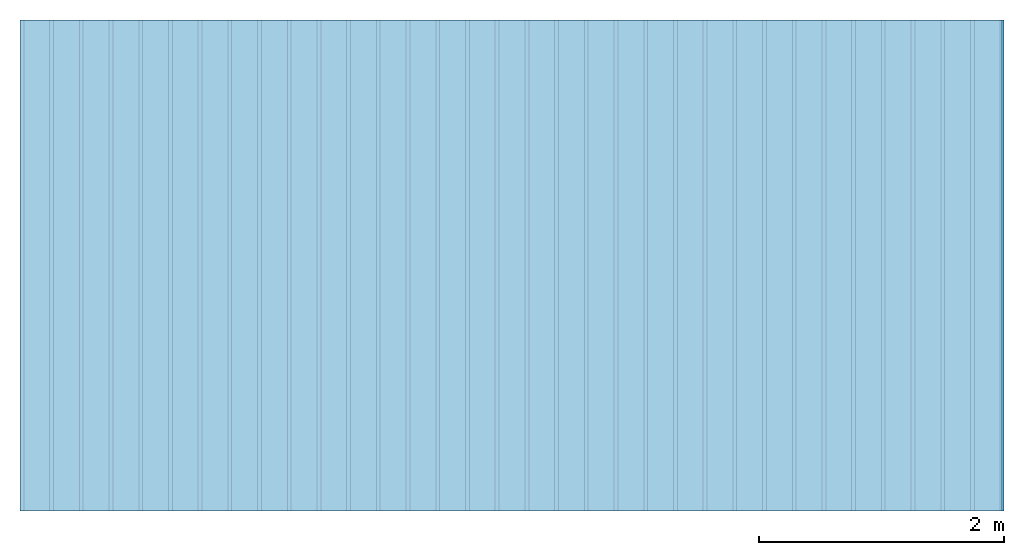
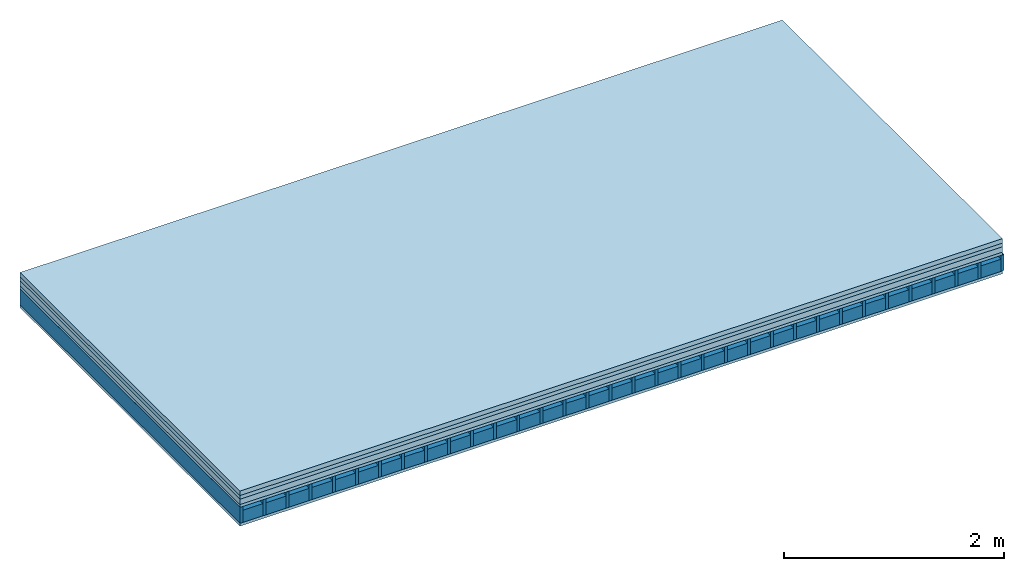
# One storey: 5 plates, 2 members, 1 element without a shape of its own.
"""IFC4 building model written with IfcOpenShell, lengths in metres."""

from ifc_helpers import new_model, si_unit, derived_unit, direction, frame, frame_2d, origin, origin_with_axes, place, context, project, spatial, rectangle, extrude, material, layer, layer_set, type_object, element, aggregate, save


model = new_model("IFC4")

# Units and contexts
plan_context = context("Plan", 3, precision=1e-05, world=origin(), true_north=direction((0.0, 1.0)))
model_context = context("Model", 3, precision=1e-05, world=origin(), true_north=direction((0.0, 1.0)))
ifc_project = project(units=[si_unit("LENGTHUNIT", "METRE"), derived_unit("SOUNDPRESSUREUNIT", [(si_unit("PRESSUREUNIT", "PASCAL", prefix="MICRO"), 0)]), si_unit("ENERGYUNIT", "JOULE", prefix="MEGA"), si_unit("MASSUNIT", "GRAM", prefix="KILO"), derived_unit("THERMALTRANSMITTANCEUNIT", [(si_unit("POWERUNIT", "WATT"), 1), (si_unit("AREAUNIT", "SQUARE_METRE"), -1), (si_unit("THERMODYNAMICTEMPERATUREUNIT", "KELVIN"), -1)]), derived_unit("AREADENSITYUNIT", [(si_unit("MASSUNIT", "GRAM", prefix="KILO"), 1), (si_unit("AREAUNIT", "SQUARE_METRE"), -1)]), derived_unit("USERDEFINED", [(si_unit("ENERGYUNIT", "JOULE", prefix="MEGA"), 1), (si_unit("AREAUNIT", "SQUARE_METRE"), -1)])], contexts=[plan_context, model_context])

# Site, building, storey
site = spatial("IfcSite", under=ifc_project)
building_placement = place(None, origin())
building = spatial("IfcBuilding", under=site, at=building_placement)
storey_placement = place(building_placement, origin())
storey = spatial("IfcBuildingStorey", under=building, at=storey_placement)

# Slab, members, plates
ifc_material_1 = material(Name="Cement screed", Category="04.006")
ifc_layer_1 = layer(ifc_material_1, 0.05, Name="On-material")
ifc_material_2 = material(Name="EP1, 40/35mm")
ifc_layer_2 = layer(ifc_material_2, 0.04, Name="Impact sound insulation")
ifc_material_3 = material(Category="03.011")
ifc_layer_3 = layer(ifc_material_3, 0.06, Name="on Supporting structure")
ifc_material_4 = material(Name="surface element sheathing above")
ifc_layer_4 = layer(ifc_material_4, 0.031, Name="Sub-floor")
ifc_layer_5 = layer(None, 0.178, Name="Supporting structure")
ifc_material_5 = material(Name="surface element acoustics type sheathing below 3")
ifc_layer_6 = layer(ifc_material_5, 0.031, Name="Lower layer 1")
ifc_layer_set = layer_set([ifc_layer_1, ifc_layer_2, ifc_layer_3, ifc_layer_4, ifc_layer_5, ifc_layer_6])
slab_type = type_object("IfcSlabType", Name="A1470", PredefinedType="NOTDEFINED", material=ifc_layer_set)
slab_placement = place(None, frame((0.0, 0.0, 0.0), z_axis=(0.0, 0.0, -1.0), x_axis=(1.0, 0.0, 0.0)))
slab = element("IfcSlab", 1, at=slab_placement, inside=storey, type_object=slab_type, material=ifc_layer_set, Name="Slab #1")
ifc_material_6 = material(Name="surface element LFE 12")
member_1_placement = place(slab_placement, origin())
member_1 = element("IfcMember", 2, at=member_1_placement, material=ifc_material_6, Name="Supporting structure", context=plan_context, shape_type="SweptSolid", body=[
    extrude(rectangle(XDim=0.031, YDim=0.178, at=frame_2d((0.0155, 0.089), x_axis=(1.0, 0.0))), frame((0.0, 4.0, 0.181), z_axis=(0.0, -1.0, 0.0), x_axis=(1.0, 0.0, 0.0)), (0.0, 0.0, 1.0), 4.0),
    extrude(rectangle(XDim=0.031, YDim=0.178, at=frame_2d((0.0155, 0.089), x_axis=(1.0, 0.0))), frame((0.242, 4.0, 0.181), z_axis=(0.0, -1.0, 0.0), x_axis=(1.0, 0.0, 0.0)), (0.0, 0.0, 1.0), 4.0),
    extrude(rectangle(XDim=0.031, YDim=0.178, at=frame_2d((0.0155, 0.089), x_axis=(1.0, 0.0))), frame((0.484, 4.0, 0.181), z_axis=(0.0, -1.0, 0.0), x_axis=(1.0, 0.0, 0.0)), (0.0, 0.0, 1.0), 4.0),
    extrude(rectangle(XDim=0.031, YDim=0.178, at=frame_2d((0.0155, 0.089), x_axis=(1.0, 0.0))), frame((0.726, 4.0, 0.181), z_axis=(0.0, -1.0, 0.0), x_axis=(1.0, 0.0, 0.0)), (0.0, 0.0, 1.0), 4.0),
    extrude(rectangle(XDim=0.031, YDim=0.178, at=frame_2d((0.0155, 0.089), x_axis=(1.0, 0.0))), frame((0.968, 4.0, 0.181), z_axis=(0.0, -1.0, 0.0), x_axis=(1.0, 0.0, 0.0)), (0.0, 0.0, 1.0), 4.0),
    extrude(rectangle(XDim=0.031, YDim=0.178, at=frame_2d((0.0155, 0.089), x_axis=(1.0, 0.0))), frame((1.21, 4.0, 0.181), z_axis=(0.0, -1.0, 0.0), x_axis=(1.0, 0.0, 0.0)), (0.0, 0.0, 1.0), 4.0),
    extrude(rectangle(XDim=0.031, YDim=0.178, at=frame_2d((0.0155, 0.089), x_axis=(1.0, 0.0))), frame((1.452, 4.0, 0.181), z_axis=(0.0, -1.0, 0.0), x_axis=(1.0, 0.0, 0.0)), (0.0, 0.0, 1.0), 4.0),
    extrude(rectangle(XDim=0.031, YDim=0.178, at=frame_2d((0.0155, 0.089), x_axis=(1.0, 0.0))), frame((1.694, 4.0, 0.181), z_axis=(0.0, -1.0, 0.0), x_axis=(1.0, 0.0, 0.0)), (0.0, 0.0, 1.0), 4.0),
    extrude(rectangle(XDim=0.031, YDim=0.178, at=frame_2d((0.0155, 0.089), x_axis=(1.0, 0.0))), frame((1.936, 4.0, 0.181), z_axis=(0.0, -1.0, 0.0), x_axis=(1.0, 0.0, 0.0)), (0.0, 0.0, 1.0), 4.0),
    extrude(rectangle(XDim=0.031, YDim=0.178, at=frame_2d((0.0155, 0.089), x_axis=(1.0, 0.0))), frame((2.178, 4.0, 0.181), z_axis=(0.0, -1.0, 0.0), x_axis=(1.0, 0.0, 0.0)), (0.0, 0.0, 1.0), 4.0),
    extrude(rectangle(XDim=0.031, YDim=0.178, at=frame_2d((0.0155, 0.089), x_axis=(1.0, 0.0))), frame((2.42, 4.0, 0.181), z_axis=(0.0, -1.0, 0.0), x_axis=(1.0, 0.0, 0.0)), (0.0, 0.0, 1.0), 4.0),
    extrude(rectangle(XDim=0.031, YDim=0.178, at=frame_2d((0.0155, 0.089), x_axis=(1.0, 0.0))), frame((2.662, 4.0, 0.181), z_axis=(0.0, -1.0, 0.0), x_axis=(1.0, 0.0, 0.0)), (0.0, 0.0, 1.0), 4.0),
    extrude(rectangle(XDim=0.031, YDim=0.178, at=frame_2d((0.0155, 0.089), x_axis=(1.0, 0.0))), frame((2.904, 4.0, 0.181), z_axis=(0.0, -1.0, 0.0), x_axis=(1.0, 0.0, 0.0)), (0.0, 0.0, 1.0), 4.0),
    extrude(rectangle(XDim=0.031, YDim=0.178, at=frame_2d((0.0155, 0.089), x_axis=(1.0, 0.0))), frame((3.146, 4.0, 0.181), z_axis=(0.0, -1.0, 0.0), x_axis=(1.0, 0.0, 0.0)), (0.0, 0.0, 1.0), 4.0),
    extrude(rectangle(XDim=0.031, YDim=0.178, at=frame_2d((0.0155, 0.089), x_axis=(1.0, 0.0))), frame((3.388, 4.0, 0.181), z_axis=(0.0, -1.0, 0.0), x_axis=(1.0, 0.0, 0.0)), (0.0, 0.0, 1.0), 4.0),
    extrude(rectangle(XDim=0.031, YDim=0.178, at=frame_2d((0.0155, 0.089), x_axis=(1.0, 0.0))), frame((3.63, 4.0, 0.181), z_axis=(0.0, -1.0, 0.0), x_axis=(1.0, 0.0, 0.0)), (0.0, 0.0, 1.0), 4.0),
    extrude(rectangle(XDim=0.031, YDim=0.178, at=frame_2d((0.0155, 0.089), x_axis=(1.0, 0.0))), frame((3.872, 4.0, 0.181), z_axis=(0.0, -1.0, 0.0), x_axis=(1.0, 0.0, 0.0)), (0.0, 0.0, 1.0), 4.0),
    extrude(rectangle(XDim=0.031, YDim=0.178, at=frame_2d((0.0155, 0.089), x_axis=(1.0, 0.0))), frame((4.114, 4.0, 0.181), z_axis=(0.0, -1.0, 0.0), x_axis=(1.0, 0.0, 0.0)), (0.0, 0.0, 1.0), 4.0),
    extrude(rectangle(XDim=0.031, YDim=0.178, at=frame_2d((0.0155, 0.089), x_axis=(1.0, 0.0))), frame((4.356, 4.0, 0.181), z_axis=(0.0, -1.0, 0.0), x_axis=(1.0, 0.0, 0.0)), (0.0, 0.0, 1.0), 4.0),
    extrude(rectangle(XDim=0.031, YDim=0.178, at=frame_2d((0.0155, 0.089), x_axis=(1.0, 0.0))), frame((4.598, 4.0, 0.181), z_axis=(0.0, -1.0, 0.0), x_axis=(1.0, 0.0, 0.0)), (0.0, 0.0, 1.0), 4.0),
    extrude(rectangle(XDim=0.031, YDim=0.178, at=frame_2d((0.0155, 0.089), x_axis=(1.0, 0.0))), frame((4.84, 4.0, 0.181), z_axis=(0.0, -1.0, 0.0), x_axis=(1.0, 0.0, 0.0)), (0.0, 0.0, 1.0), 4.0),
    extrude(rectangle(XDim=0.031, YDim=0.178, at=frame_2d((0.0155, 0.089), x_axis=(1.0, 0.0))), frame((5.082, 4.0, 0.181), z_axis=(0.0, -1.0, 0.0), x_axis=(1.0, 0.0, 0.0)), (0.0, 0.0, 1.0), 4.0),
    extrude(rectangle(XDim=0.031, YDim=0.178, at=frame_2d((0.0155, 0.089), x_axis=(1.0, 0.0))), frame((5.324, 4.0, 0.181), z_axis=(0.0, -1.0, 0.0), x_axis=(1.0, 0.0, 0.0)), (0.0, 0.0, 1.0), 4.0),
    extrude(rectangle(XDim=0.031, YDim=0.178, at=frame_2d((0.0155, 0.089), x_axis=(1.0, 0.0))), frame((5.566, 4.0, 0.181), z_axis=(0.0, -1.0, 0.0), x_axis=(1.0, 0.0, 0.0)), (0.0, 0.0, 1.0), 4.0),
    extrude(rectangle(XDim=0.031, YDim=0.178, at=frame_2d((0.0155, 0.089), x_axis=(1.0, 0.0))), frame((5.808, 4.0, 0.181), z_axis=(0.0, -1.0, 0.0), x_axis=(1.0, 0.0, 0.0)), (0.0, 0.0, 1.0), 4.0),
    extrude(rectangle(XDim=0.031, YDim=0.178, at=frame_2d((0.0155, 0.089), x_axis=(1.0, 0.0))), frame((6.05, 4.0, 0.181), z_axis=(0.0, -1.0, 0.0), x_axis=(1.0, 0.0, 0.0)), (0.0, 0.0, 1.0), 4.0),
    extrude(rectangle(XDim=0.031, YDim=0.178, at=frame_2d((0.0155, 0.089), x_axis=(1.0, 0.0))), frame((6.292, 4.0, 0.181), z_axis=(0.0, -1.0, 0.0), x_axis=(1.0, 0.0, 0.0)), (0.0, 0.0, 1.0), 4.0),
    extrude(rectangle(XDim=0.031, YDim=0.178, at=frame_2d((0.0155, 0.089), x_axis=(1.0, 0.0))), frame((6.534, 4.0, 0.181), z_axis=(0.0, -1.0, 0.0), x_axis=(1.0, 0.0, 0.0)), (0.0, 0.0, 1.0), 4.0),
    extrude(rectangle(XDim=0.031, YDim=0.178, at=frame_2d((0.0155, 0.089), x_axis=(1.0, 0.0))), frame((6.776, 4.0, 0.181), z_axis=(0.0, -1.0, 0.0), x_axis=(1.0, 0.0, 0.0)), (0.0, 0.0, 1.0), 4.0),
    extrude(rectangle(XDim=0.031, YDim=0.178, at=frame_2d((0.0155, 0.089), x_axis=(1.0, 0.0))), frame((7.018, 4.0, 0.181), z_axis=(0.0, -1.0, 0.0), x_axis=(1.0, 0.0, 0.0)), (0.0, 0.0, 1.0), 4.0),
    extrude(rectangle(XDim=0.031, YDim=0.178, at=frame_2d((0.0155, 0.089), x_axis=(1.0, 0.0))), frame((7.26, 4.0, 0.181), z_axis=(0.0, -1.0, 0.0), x_axis=(1.0, 0.0, 0.0)), (0.0, 0.0, 1.0), 4.0),
    extrude(rectangle(XDim=0.031, YDim=0.178, at=frame_2d((0.0155, 0.089), x_axis=(1.0, 0.0))), frame((7.502, 4.0, 0.181), z_axis=(0.0, -1.0, 0.0), x_axis=(1.0, 0.0, 0.0)), (0.0, 0.0, 1.0), 4.0),
    extrude(rectangle(XDim=0.031, YDim=0.178, at=frame_2d((0.0155, 0.089), x_axis=(1.0, 0.0))), frame((7.744, 4.0, 0.181), z_axis=(0.0, -1.0, 0.0), x_axis=(1.0, 0.0, 0.0)), (0.0, 0.0, 1.0), 4.0),
    extrude(rectangle(XDim=0.031, YDim=0.178, at=frame_2d((0.0155, 0.089), x_axis=(1.0, 0.0))), frame((7.986, 4.0, 0.181), z_axis=(0.0, -1.0, 0.0), x_axis=(1.0, 0.0, 0.0)), (0.0, 0.0, 1.0), 4.0),
])
ifc_material_7 = material(Name="Damper LFE 12")
member_2_placement = place(slab_placement, origin())
member_2 = element("IfcMember", 3, at=member_2_placement, material=ifc_material_7, Name="in supporting structure", context=plan_context, shape_type="SweptSolid", body=[
    extrude(rectangle(XDim=0.211, YDim=0.135, at=frame_2d((0.1055, 0.0675), x_axis=(1.0, 0.0))), frame((0.031, 4.0, 0.224), z_axis=(0.0, -1.0, 0.0), x_axis=(1.0, 0.0, 0.0)), (0.0, 0.0, 1.0), 4.0),
    extrude(rectangle(XDim=0.211, YDim=0.135, at=frame_2d((0.1055, 0.0675), x_axis=(1.0, 0.0))), frame((0.273, 4.0, 0.224), z_axis=(0.0, -1.0, 0.0), x_axis=(1.0, 0.0, 0.0)), (0.0, 0.0, 1.0), 4.0),
    extrude(rectangle(XDim=0.211, YDim=0.135, at=frame_2d((0.1055, 0.0675), x_axis=(1.0, 0.0))), frame((0.515, 4.0, 0.224), z_axis=(0.0, -1.0, 0.0), x_axis=(1.0, 0.0, 0.0)), (0.0, 0.0, 1.0), 4.0),
    extrude(rectangle(XDim=0.211, YDim=0.135, at=frame_2d((0.1055, 0.0675), x_axis=(1.0, 0.0))), frame((0.757, 4.0, 0.224), z_axis=(0.0, -1.0, 0.0), x_axis=(1.0, 0.0, 0.0)), (0.0, 0.0, 1.0), 4.0),
    extrude(rectangle(XDim=0.211, YDim=0.135, at=frame_2d((0.1055, 0.0675), x_axis=(1.0, 0.0))), frame((0.999, 4.0, 0.224), z_axis=(0.0, -1.0, 0.0), x_axis=(1.0, 0.0, 0.0)), (0.0, 0.0, 1.0), 4.0),
    extrude(rectangle(XDim=0.211, YDim=0.135, at=frame_2d((0.1055, 0.0675), x_axis=(1.0, 0.0))), frame((1.241, 4.0, 0.224), z_axis=(0.0, -1.0, 0.0), x_axis=(1.0, 0.0, 0.0)), (0.0, 0.0, 1.0), 4.0),
    extrude(rectangle(XDim=0.211, YDim=0.135, at=frame_2d((0.1055, 0.0675), x_axis=(1.0, 0.0))), frame((1.483, 4.0, 0.224), z_axis=(0.0, -1.0, 0.0), x_axis=(1.0, 0.0, 0.0)), (0.0, 0.0, 1.0), 4.0),
    extrude(rectangle(XDim=0.211, YDim=0.135, at=frame_2d((0.1055, 0.0675), x_axis=(1.0, 0.0))), frame((1.725, 4.0, 0.224), z_axis=(0.0, -1.0, 0.0), x_axis=(1.0, 0.0, 0.0)), (0.0, 0.0, 1.0), 4.0),
    extrude(rectangle(XDim=0.211, YDim=0.135, at=frame_2d((0.1055, 0.0675), x_axis=(1.0, 0.0))), frame((1.967, 4.0, 0.224), z_axis=(0.0, -1.0, 0.0), x_axis=(1.0, 0.0, 0.0)), (0.0, 0.0, 1.0), 4.0),
    extrude(rectangle(XDim=0.211, YDim=0.135, at=frame_2d((0.1055, 0.0675), x_axis=(1.0, 0.0))), frame((2.209, 4.0, 0.224), z_axis=(0.0, -1.0, 0.0), x_axis=(1.0, 0.0, 0.0)), (0.0, 0.0, 1.0), 4.0),
    extrude(rectangle(XDim=0.211, YDim=0.135, at=frame_2d((0.1055, 0.0675), x_axis=(1.0, 0.0))), frame((2.451, 4.0, 0.224), z_axis=(0.0, -1.0, 0.0), x_axis=(1.0, 0.0, 0.0)), (0.0, 0.0, 1.0), 4.0),
    extrude(rectangle(XDim=0.211, YDim=0.135, at=frame_2d((0.1055, 0.0675), x_axis=(1.0, 0.0))), frame((2.693, 4.0, 0.224), z_axis=(0.0, -1.0, 0.0), x_axis=(1.0, 0.0, 0.0)), (0.0, 0.0, 1.0), 4.0),
    extrude(rectangle(XDim=0.211, YDim=0.135, at=frame_2d((0.1055, 0.0675), x_axis=(1.0, 0.0))), frame((2.935, 4.0, 0.224), z_axis=(0.0, -1.0, 0.0), x_axis=(1.0, 0.0, 0.0)), (0.0, 0.0, 1.0), 4.0),
    extrude(rectangle(XDim=0.211, YDim=0.135, at=frame_2d((0.1055, 0.0675), x_axis=(1.0, 0.0))), frame((3.177, 4.0, 0.224), z_axis=(0.0, -1.0, 0.0), x_axis=(1.0, 0.0, 0.0)), (0.0, 0.0, 1.0), 4.0),
    extrude(rectangle(XDim=0.211, YDim=0.135, at=frame_2d((0.1055, 0.0675), x_axis=(1.0, 0.0))), frame((3.419, 4.0, 0.224), z_axis=(0.0, -1.0, 0.0), x_axis=(1.0, 0.0, 0.0)), (0.0, 0.0, 1.0), 4.0),
    extrude(rectangle(XDim=0.211, YDim=0.135, at=frame_2d((0.1055, 0.0675), x_axis=(1.0, 0.0))), frame((3.661, 4.0, 0.224), z_axis=(0.0, -1.0, 0.0), x_axis=(1.0, 0.0, 0.0)), (0.0, 0.0, 1.0), 4.0),
    extrude(rectangle(XDim=0.211, YDim=0.135, at=frame_2d((0.1055, 0.0675), x_axis=(1.0, 0.0))), frame((3.903, 4.0, 0.224), z_axis=(0.0, -1.0, 0.0), x_axis=(1.0, 0.0, 0.0)), (0.0, 0.0, 1.0), 4.0),
    extrude(rectangle(XDim=0.211, YDim=0.135, at=frame_2d((0.1055, 0.0675), x_axis=(1.0, 0.0))), frame((4.145, 4.0, 0.224), z_axis=(0.0, -1.0, 0.0), x_axis=(1.0, 0.0, 0.0)), (0.0, 0.0, 1.0), 4.0),
    extrude(rectangle(XDim=0.211, YDim=0.135, at=frame_2d((0.1055, 0.0675), x_axis=(1.0, 0.0))), frame((4.387, 4.0, 0.224), z_axis=(0.0, -1.0, 0.0), x_axis=(1.0, 0.0, 0.0)), (0.0, 0.0, 1.0), 4.0),
    extrude(rectangle(XDim=0.211, YDim=0.135, at=frame_2d((0.1055, 0.0675), x_axis=(1.0, 0.0))), frame((4.629, 4.0, 0.224), z_axis=(0.0, -1.0, 0.0), x_axis=(1.0, 0.0, 0.0)), (0.0, 0.0, 1.0), 4.0),
    extrude(rectangle(XDim=0.211, YDim=0.135, at=frame_2d((0.1055, 0.0675), x_axis=(1.0, 0.0))), frame((4.871, 4.0, 0.224), z_axis=(0.0, -1.0, 0.0), x_axis=(1.0, 0.0, 0.0)), (0.0, 0.0, 1.0), 4.0),
    extrude(rectangle(XDim=0.211, YDim=0.135, at=frame_2d((0.1055, 0.0675), x_axis=(1.0, 0.0))), frame((5.113, 4.0, 0.224), z_axis=(0.0, -1.0, 0.0), x_axis=(1.0, 0.0, 0.0)), (0.0, 0.0, 1.0), 4.0),
    extrude(rectangle(XDim=0.211, YDim=0.135, at=frame_2d((0.1055, 0.0675), x_axis=(1.0, 0.0))), frame((5.355, 4.0, 0.224), z_axis=(0.0, -1.0, 0.0), x_axis=(1.0, 0.0, 0.0)), (0.0, 0.0, 1.0), 4.0),
    extrude(rectangle(XDim=0.211, YDim=0.135, at=frame_2d((0.1055, 0.0675), x_axis=(1.0, 0.0))), frame((5.597, 4.0, 0.224), z_axis=(0.0, -1.0, 0.0), x_axis=(1.0, 0.0, 0.0)), (0.0, 0.0, 1.0), 4.0),
    extrude(rectangle(XDim=0.211, YDim=0.135, at=frame_2d((0.1055, 0.0675), x_axis=(1.0, 0.0))), frame((5.839, 4.0, 0.224), z_axis=(0.0, -1.0, 0.0), x_axis=(1.0, 0.0, 0.0)), (0.0, 0.0, 1.0), 4.0),
    extrude(rectangle(XDim=0.211, YDim=0.135, at=frame_2d((0.1055, 0.0675), x_axis=(1.0, 0.0))), frame((6.081, 4.0, 0.224), z_axis=(0.0, -1.0, 0.0), x_axis=(1.0, 0.0, 0.0)), (0.0, 0.0, 1.0), 4.0),
    extrude(rectangle(XDim=0.211, YDim=0.135, at=frame_2d((0.1055, 0.0675), x_axis=(1.0, 0.0))), frame((6.323, 4.0, 0.224), z_axis=(0.0, -1.0, 0.0), x_axis=(1.0, 0.0, 0.0)), (0.0, 0.0, 1.0), 4.0),
    extrude(rectangle(XDim=0.211, YDim=0.135, at=frame_2d((0.1055, 0.0675), x_axis=(1.0, 0.0))), frame((6.565, 4.0, 0.224), z_axis=(0.0, -1.0, 0.0), x_axis=(1.0, 0.0, 0.0)), (0.0, 0.0, 1.0), 4.0),
    extrude(rectangle(XDim=0.211, YDim=0.135, at=frame_2d((0.1055, 0.0675), x_axis=(1.0, 0.0))), frame((6.807, 4.0, 0.224), z_axis=(0.0, -1.0, 0.0), x_axis=(1.0, 0.0, 0.0)), (0.0, 0.0, 1.0), 4.0),
    extrude(rectangle(XDim=0.211, YDim=0.135, at=frame_2d((0.1055, 0.0675), x_axis=(1.0, 0.0))), frame((7.049, 4.0, 0.224), z_axis=(0.0, -1.0, 0.0), x_axis=(1.0, 0.0, 0.0)), (0.0, 0.0, 1.0), 4.0),
    extrude(rectangle(XDim=0.211, YDim=0.135, at=frame_2d((0.1055, 0.0675), x_axis=(1.0, 0.0))), frame((7.291, 4.0, 0.224), z_axis=(0.0, -1.0, 0.0), x_axis=(1.0, 0.0, 0.0)), (0.0, 0.0, 1.0), 4.0),
    extrude(rectangle(XDim=0.211, YDim=0.135, at=frame_2d((0.1055, 0.0675), x_axis=(1.0, 0.0))), frame((7.533, 4.0, 0.224), z_axis=(0.0, -1.0, 0.0), x_axis=(1.0, 0.0, 0.0)), (0.0, 0.0, 1.0), 4.0),
    extrude(rectangle(XDim=0.211, YDim=0.135, at=frame_2d((0.1055, 0.0675), x_axis=(1.0, 0.0))), frame((7.775, 4.0, 0.224), z_axis=(0.0, -1.0, 0.0), x_axis=(1.0, 0.0, 0.0)), (0.0, 0.0, 1.0), 4.0),
])
plate_1_placement = place(slab_placement, origin())
plate_1 = element("IfcPlate", 4, at=plate_1_placement, material=ifc_material_1, Name="On-material", context=plan_context, shape_type="SweptSolid", body=[
    extrude(rectangle(XDim=8.0, YDim=4.0, at=frame_2d((4.0, 2.0), x_axis=(1.0, 0.0))), origin_with_axes(), (0.0, 0.0, 1.0), 0.05),
])
plate_2_placement = place(slab_placement, origin())
plate_2 = element("IfcPlate", 5, at=plate_2_placement, material=ifc_material_2, Name="Impact sound insulation", context=plan_context, shape_type="SweptSolid", body=[
    extrude(rectangle(XDim=8.0, YDim=4.0, at=frame_2d((4.0, 2.0), x_axis=(1.0, 0.0))), frame((0.0, 0.0, 0.05), z_axis=(0.0, 0.0, 1.0), x_axis=(1.0, 0.0, 0.0)), (0.0, 0.0, 1.0), 0.04),
])
plate_3_placement = place(slab_placement, origin())
plate_3 = element("IfcPlate", 6, at=plate_3_placement, material=ifc_material_3, Name="on Supporting structure", context=plan_context, shape_type="SweptSolid", body=[
    extrude(rectangle(XDim=8.0, YDim=4.0, at=frame_2d((4.0, 2.0), x_axis=(1.0, 0.0))), frame((0.0, 0.0, 0.09), z_axis=(0.0, 0.0, 1.0), x_axis=(1.0, 0.0, 0.0)), (0.0, 0.0, 1.0), 0.06),
])
plate_4_placement = place(slab_placement, origin())
plate_4 = element("IfcPlate", 7, at=plate_4_placement, material=ifc_material_4, Name="Sub-floor", context=plan_context, shape_type="SweptSolid", body=[
    extrude(rectangle(XDim=8.0, YDim=4.0, at=frame_2d((4.0, 2.0), x_axis=(1.0, 0.0))), frame((0.0, 0.0, 0.15), z_axis=(0.0, 0.0, 1.0), x_axis=(1.0, 0.0, 0.0)), (0.0, 0.0, 1.0), 0.031),
])
plate_5_placement = place(slab_placement, origin())
plate_5 = element("IfcPlate", 8, at=plate_5_placement, material=ifc_material_5, Name="Lower layer 1", context=plan_context, shape_type="SweptSolid", body=[
    extrude(rectangle(XDim=8.0, YDim=4.0, at=frame_2d((4.0, 2.0), x_axis=(1.0, 0.0))), frame((0.0, 0.0, 0.359), z_axis=(0.0, 0.0, 1.0), x_axis=(1.0, 0.0, 0.0)), (0.0, 0.0, 1.0), 0.031),
])
aggregate(slab, [plate_1, plate_2, plate_3, plate_4, member_1, member_2, plate_5])

save(model, "model.ifc")
